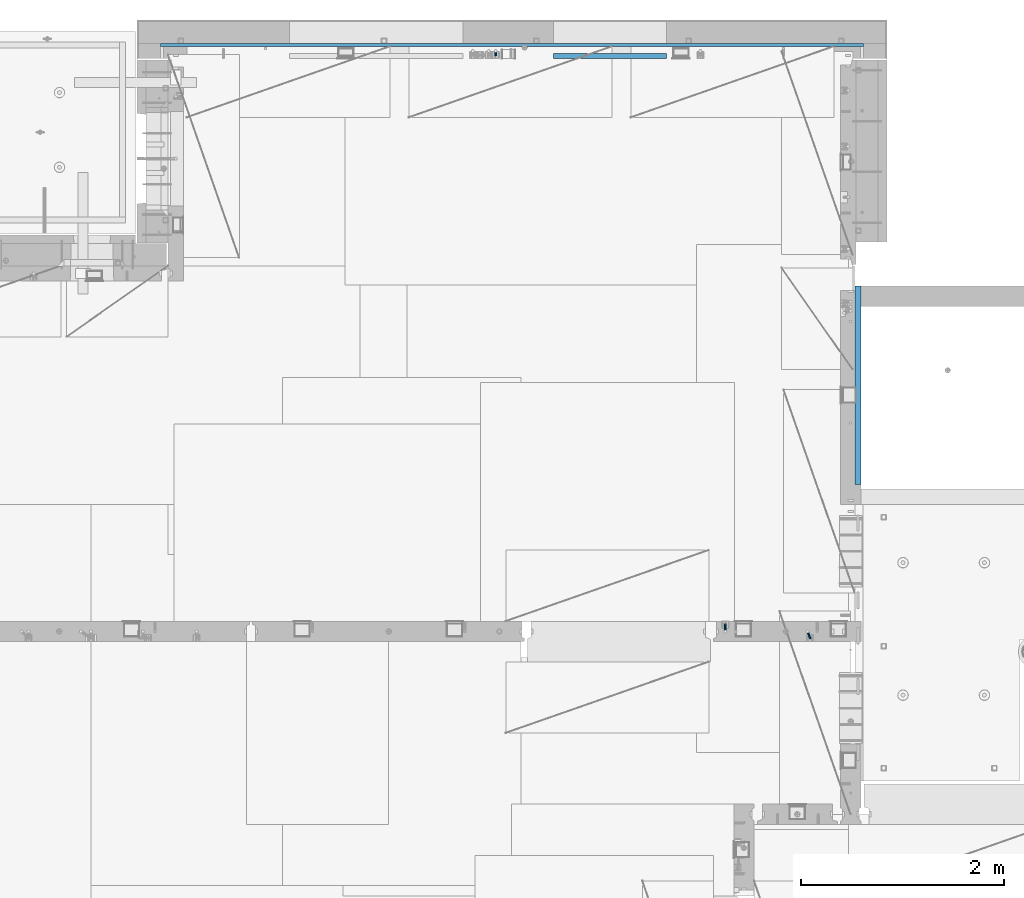
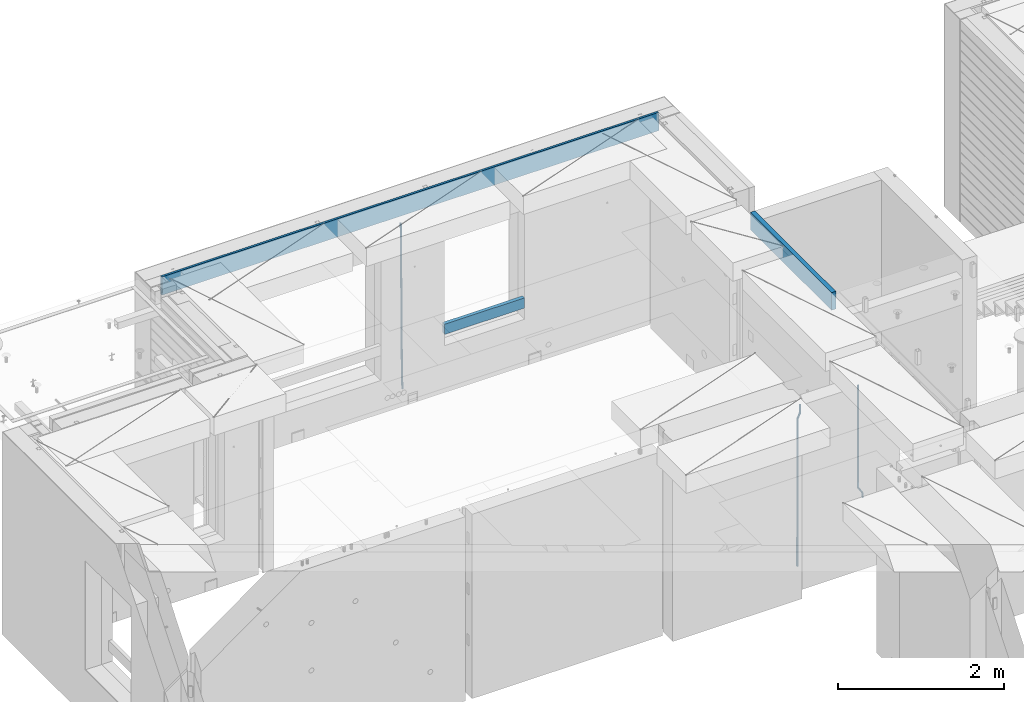
# One storey, part 112 of 334: 6 beams, 3 elements without a shape of their own.
"""IFC2X3 building model written with IfcOpenShell, lengths in millimetres."""

import ifcopenshell
import ifcopenshell.guid

model = None  # the IFC model being written
_history = None  # IfcOwnerHistory: only IFC2X3 demands one
_inside = {}  # id of a spatial element -> (the spatial element, [elements in it])
_under = {}  # id of a project, library or spatial element -> (it, [spatial elements below it])
_declared = {}  # id of a project -> (the project, [libraries it declares])
_typed = {}  # id of a type object -> (the type object, [elements of that type])
_made_of = {}  # id of a material, layer set ... -> (it, [elements and type objects made of it])


def new_model(schema):
    """Start an empty IFC model of exactly this schema.

    Asked for "IFC4X3", IfcOpenShell would pick the latest addendum, in which some entities
    have other attributes; the version numbers below select the first issue.
    IFC2X3 requires an IfcOwnerHistory on every rooted entity: one is made here for all.
    """
    global model, _history
    if schema == "IFC4X3":
        model = ifcopenshell.file(schema_version=(4, 3, 0, 0))
    else:
        model = ifcopenshell.file(schema=schema)
    _inside.clear()
    _under.clear()
    _declared.clear()
    _typed.clear()
    _made_of.clear()
    _history = None
    if model.schema == "IFC2X3":
        org = make("IfcOrganization", Name="unknown")
        user = make(
            "IfcPersonAndOrganization",
            ThePerson=make("IfcPerson", FamilyName="unknown"),
            TheOrganization=org,
        )
        app = make(
            "IfcApplication",
            ApplicationDeveloper=org,
            Version="unknown",
            ApplicationFullName="unknown",
            ApplicationIdentifier="unknown",
        )
        _history = make(
            "IfcOwnerHistory",
            OwningUser=user,
            OwningApplication=app,
            ChangeAction="ADDED",
            CreationDate=0,
        )
    return model


def make(cls, **values):
    """One entity of the class cls with the attributes given. An attribute that is None is left unset."""
    return model.create_entity(
        cls, **{name: value for name, value in values.items() if value is not None}
    )


def rooted(cls, **values):
    """An entity with a GlobalId (a new one), such as an element, a storey or a relation."""
    return make(cls, GlobalId=ifcopenshell.guid.new(), OwnerHistory=_history, **values)


def si_unit(unit_type, name, prefix=None):
    """IfcSIUnit, for example si_unit("LENGTHUNIT", "METRE", prefix="MILLI")."""
    return make("IfcSIUnit", UnitType=unit_type, Prefix=prefix, Name=name)


def assignment(units):
    """IfcUnitAssignment: the units of a project."""
    return None if units is None else make("IfcUnitAssignment", Units=units)


def point(xyz):
    """IfcCartesianPoint."""
    return None if xyz is None else make("IfcCartesianPoint", Coordinates=xyz)


def direction(xyz):
    """IfcDirection."""
    return None if xyz is None else make("IfcDirection", DirectionRatios=xyz)


def frame(location, z_axis=None, x_axis=None):
    """IfcAxis2Placement3D, a coordinate frame: its origin and axes. An axis left out is left unset."""
    return make(
        "IfcAxis2Placement3D",
        Location=point(location),
        Axis=direction(z_axis),
        RefDirection=direction(x_axis),
    )


def origin_with_axes():
    """The frame at (0, 0, 0) with the z axis (0, 0, 1) and the x axis (1, 0, 0) written out."""
    return frame((0.0, 0.0, 0.0), z_axis=(0.0, 0.0, 1.0), x_axis=(1.0, 0.0, 0.0))


def place(relative_to, where):
    """IfcLocalPlacement: puts the frame where relative to a parent placement (None: the world)."""
    return make(
        "IfcLocalPlacement", PlacementRelTo=relative_to, RelativePlacement=where
    )


def context(
    kind, dimensions, precision=None, world=None, true_north=None, identifier=None
):
    """IfcGeometricRepresentationContext, for example the 3D "Model" context."""
    return make(
        "IfcGeometricRepresentationContext",
        ContextIdentifier=identifier,
        ContextType=kind,
        CoordinateSpaceDimension=dimensions,
        Precision=precision,
        WorldCoordinateSystem=world,
        TrueNorth=true_north,
    )


def subcontext(parent, identifier, kind, view, scale=None):
    """IfcGeometricRepresentationSubContext, for example "Body" below "Model"."""
    return make(
        "IfcGeometricRepresentationSubContext",
        ContextIdentifier=identifier,
        ContextType=kind,
        ParentContext=parent,
        TargetScale=scale,
        TargetView=view,
    )


def project(units=None, contexts=None):
    """IfcProject with its units and contexts."""
    return rooted(
        "IfcProject",
        Name="project",
        RepresentationContexts=contexts,
        UnitsInContext=assignment(units),
    )


def spatial(cls, under=None, at=None, **own):
    """A site, building, storey or space (cls), placed at a placement, below another one or the project."""
    s = rooted(cls, ObjectPlacement=at, **own)
    if under is not None:
        _under.setdefault(under.id(), (under, []))[1].append(s)
    return s


def faces_of(points, faces, orient=None, outer=None):
    """IfcFace entities. A face is a list of loops; a loop is a list of indices into points, from 0.

    orient and outer hold one flag for each loop. By default every Orientation is true, the
    first loop of a face is its IfcFaceOuterBound and the others are IfcFaceBound.
    """
    made = []
    for i, loops in enumerate(faces):
        bounds = []
        for j, loop in enumerate(loops):
            is_outer = j == 0 if outer is None else outer[i][j]
            bounds.append(
                make(
                    "IfcFaceOuterBound" if is_outer else "IfcFaceBound",
                    Bound=make("IfcPolyLoop", Polygon=[points[k] for k in loop]),
                    Orientation=True if orient is None else orient[i][j],
                )
            )
        made.append(make("IfcFace", Bounds=bounds))
    return made


def faceted_brep(points, faces, orient=None, outer=None, voids=None):
    """IfcFacetedBrep: a solid bounded by flat faces; with voids (closed shells), ...WithVoids."""
    shared = [point(p) for p in points]
    hull = make("IfcClosedShell", CfsFaces=faces_of(shared, faces, orient, outer))
    if voids is None:
        return make("IfcFacetedBrep", Outer=hull)
    return make(
        "IfcFacetedBrepWithVoids",
        Outer=hull,
        Voids=[
            make(cls, CfsFaces=faces_of(shared, fs, o, b)) for cls, fs, o, b in voids
        ],
    )


def shape(context_of_items, identifier, shape_type, items):
    """IfcShapeRepresentation: the items that make up one representation, for example the "Body"."""
    return make(
        "IfcShapeRepresentation",
        ContextOfItems=context_of_items,
        RepresentationIdentifier=identifier,
        RepresentationType=shape_type,
        Items=items,
    )


def material(Name=None, Category=None):
    """IfcMaterial."""
    return make("IfcMaterial", Name=Name, Category=Category)


def made_of(thing, what):
    """Note that an element or type object is made of a material, layer set ...; save() writes the relation."""
    if what is not None:
        _made_of.setdefault(what.id(), (what, []))[1].append(thing)
    return thing


def type_object(cls, material=None, **own):
    """A type object (cls), such as IfcWallType, which elements share."""
    return made_of(rooted(cls, **own), material)


def element(
    cls,
    number,
    at=None,
    inside=None,
    cuts=None,
    type_object=None,
    material=None,
    context=None,
    identifier="Body",
    shape_type=None,
    held_by="IfcProductDefinitionShape",
    body=None,
    shapes=None,
    **own,
):
    """One element of the class cls, such as IfcWall. Its Tag is "e" and its number.

    at: its placement. inside: the storey or other place that contains it. cuts: it is an
    opening in that element (IfcRelVoidsElement). A single representation is given by context,
    identifier, shape_type and body (its items); several are given by shapes. held_by: the class
    of the entity that holds the representations. save() writes the other relations.
    """
    e = rooted(cls, Tag="e%d" % number, ObjectPlacement=at, **own)
    if body is not None:
        shapes = [shape(context, identifier, shape_type, body)]
    if shapes is not None:
        e.Representation = make(held_by, Representations=shapes)
    if inside is not None:
        _inside.setdefault(inside.id(), (inside, []))[1].append(e)
    if cuts is not None:
        rooted(
            "IfcRelVoidsElement", RelatingBuildingElement=cuts, RelatedOpeningElement=e
        )
    if type_object is not None:
        _typed.setdefault(type_object.id(), (type_object, []))[1].append(e)
    return made_of(e, material)


def aggregate(whole, parts):
    """IfcRelAggregates: a whole, such as a stair, and the parts it consists of."""
    return rooted("IfcRelAggregates", RelatingObject=whole, RelatedObjects=parts)


def save(model, path):
    """Write the relations noted so far, then the file.

    IfcRelAggregates (storeys below a building ...), IfcRelContainedInSpatialStructure (elements
    in a storey), IfcRelDefinesByType, IfcRelAssociatesMaterial and IfcRelDeclares: one each for
    every whole, place, type object, material and project.
    """
    for whole, parts in _under.values():
        aggregate(whole, parts)
    for where, things in _inside.values():
        rooted(
            "IfcRelContainedInSpatialStructure",
            RelatedElements=things,
            RelatingStructure=where,
        )
    for kind, things in _typed.values():
        rooted("IfcRelDefinesByType", RelatedObjects=things, RelatingType=kind)
    for what, things in _made_of.values():
        rooted("IfcRelAssociatesMaterial", RelatedObjects=things, RelatingMaterial=what)
    for by, libraries in _declared.values():
        rooted("IfcRelDeclares", RelatingContext=by, RelatedDefinitions=libraries)
    model.write(path)


model = new_model("IFC2X3")

# Units and contexts
model_context = context("Model", 3, precision=1e-05, world=origin_with_axes())
body_context = subcontext(model_context, "Body", "Model", "MODEL_VIEW")
ifc_project = project(units=[si_unit("LENGTHUNIT", "METRE", prefix="MILLI"), si_unit("AREAUNIT", "SQUARE_METRE"), si_unit("VOLUMEUNIT", "CUBIC_METRE"), si_unit("MASSUNIT", "GRAM", prefix="KILO"), si_unit("TIMEUNIT", "SECOND"), si_unit("PLANEANGLEUNIT", "RADIAN"), si_unit("SOLIDANGLEUNIT", "STERADIAN"), si_unit("THERMODYNAMICTEMPERATUREUNIT", "DEGREE_CELSIUS"), si_unit("LUMINOUSINTENSITYUNIT", "LUMEN")], contexts=[model_context])

# Site, building, storey
site_placement = place(None, origin_with_axes())
site = spatial("IfcSite", under=ifc_project, at=site_placement, CompositionType="ELEMENT")
building_placement = place(site_placement, origin_with_axes())
building = spatial("IfcBuilding", under=site, at=building_placement, CompositionType="ELEMENT")
storey_placement = place(building_placement, origin_with_axes())
storey = spatial("IfcBuildingStorey", under=building, at=storey_placement, Name="3", CompositionType="ELEMENT", Elevation=0.0)

# Assembly, beams
assembly_1_placement = place(storey_placement, origin_with_axes())
assembly_1 = element("IfcElementAssembly", 1, at=assembly_1_placement, inside=storey, AssemblyPlace="NOTDEFINED", PredefinedType="REINFORCEMENT_UNIT")
ifc_material_1 = material()
beam_type_1 = type_object("IfcBeamType", Name="D20", PredefinedType="NOTDEFINED")
beam_1_placement = place(assembly_1_placement, frame((17285.016478657, 16980.0, 90407.5), z_axis=(-0.000415599999849952, -0.999999913638316, 0.0), x_axis=(-6.05680000062309e-05, -4.00000390151988e-09, -0.999999998165759)))
beam_1 = element("IfcBeam", 2, at=beam_1_placement, type_object=beam_type_1, material=ifc_material_1, Name="JM20", ObjectType="D20", context=body_context, shape_type="Brep", body=[
    faceted_brep([(0.000459931368823163, -9.99999998942076, 0.0), (0.000325058383168653, -7.07106780439426, -7.07106781187031), (1498.53016917036, -7.00214571310062, -7.07110244258729), (1498.53030404639, -9.93107788867201, -3.46394881489687e-05), (0.0, 0.0, -10.0), (1498.52984388257, 0.0689220912790915, -10.0000346307206), (-0.000325382832670584, 7.07106780437971, -7.07106781186667), (1498.52951872915, 7.13998989566971, -7.07110244258365), (-0.000459931412478909, 9.9999999894244, 0.0), (1498.52938418057, 10.0689220807144, -3.46307206200436e-05), (-0.000325058426824398, 7.07106780439062, 7.07106781186667), (1498.52951905355, 7.13998989568427, 7.07103318114605), (0.0, 0.0, 10.0), (1498.52984434133, 0.0689220913009194, 9.99996536927938), (0.000325382789014839, -7.07106780437607, 7.07106781186303), (1498.53016949476, -7.00214571308607, 7.07103318114241), (1512.41720874803, -5.73582294623338, -3.78448857876356), (1509.77427058959, -8.90577003658836, 2.66104918808924), (1506.12781116656, -6.30933666407145, 8.86914963737581), (1503.61387695429, 0.5325217154641, 11.203191722434), (1503.70509651935, 7.6119372551475, 8.29592524499458), (1506.34803467779, 10.7818843455061, 1.85038747814542), (1509.99449410092, 8.18545097300375, -4.35771297110477), (1512.50842831319, 1.34359259344637, -6.6917550561775), (1523.10793428493, 4.85819958866705, 2.43339327473223), (1522.94729923509, -2.24423288682374, 5.28089974098111), (1518.68801206884, 11.068066365151, 3.12656423834051), (1512.27666307625, 12.7477117054659, 6.95436248228361), (1507.62956859401, 8.91322214926913, 11.6745157093537), (1507.46893354415, 1.81078967378926, 14.5220221756208), (1511.88885576031, -4.39907710268017, 13.8288512120525), (1518.30020474852, -6.07872245333419, 10.0010529750907), (1556.47190306216, 16.2553988912259, 53.3150705600565), (1551.82480858495, 12.4209093455574, 58.0352237797015), (1556.63253811194, 23.3578313666767, 50.4675640938258), (1552.2126158958, 29.5676981431861, 51.1607350575687), (1545.80126690332, 31.2473434836029, 54.9885333017664), (1541.1541724212, 27.4128539274789, 59.7086865290003), (1540.99353737144, 20.3104214520208, 62.5561929952273), (1545.41345958759, 14.100554675515, 61.8630220314881), (1560.39637396604, 17.5567067062075, 56.6936612143036), (1557.75345399432, 14.386777545431, 63.1392152562548), (1554.10697584673, 16.9832211248868, 69.3473004384578), (1551.59299696748, 23.8250760096525, 71.6813046576062), (1551.6841720884, 30.9044764000282, 68.7739998967481), (1554.32709206025, 34.0744055607975, 62.3284458548405), (1557.97357020773, 31.4779619813417, 56.1203606726085), (1560.48754908697, 24.6361070965759, 53.7863564534418), (1565.57152260729, 25.0997628321384, 54.9895678972971), (1565.57195097132, 18.0287166318594, 57.9185522284643), (1565.57109441068, 32.1708522292429, 57.9184479422765), (1565.5709172132, 35.0998365550477, 64.9894941556158), (1565.57109481466, 32.1709565155361, 72.0605835657152), (1565.57152317863, 25.0999103152426, 74.9895678968714), (1565.5719513753, 18.0288209181526, 72.0606878518956), (1565.57212857006, 15.0998365824271, 64.9896416479532), (1617.49891294041, 18.0318617339399, 57.9185507229813), (1617.49909054188, 15.1029816944028, 64.9896401330443), (1617.49848457637, 25.1029079342443, 54.989566391796), (1617.49805637961, 32.1739973313524, 57.9184464367172), (1617.49787918197, 35.1029816571718, 64.9894926500019), (1617.49805678344, 32.1741016176347, 72.0605820600649), (1617.49848514747, 25.1030554173267, 74.9895663912539), (1617.49891334424, 18.0319660202294, 72.060686346329)], [[[0, 1, 2, 3]], [[1, 4, 5, 2]], [[4, 6, 7, 5]], [[6, 8, 9, 7]], [[8, 10, 11, 9]], [[10, 12, 13, 11]], [[12, 14, 15, 13]], [[14, 0, 3, 15]], [[14, 12, 10, 8, 6, 4, 1, 0]], [[3, 2, 16, 17]], [[15, 3, 17, 18]], [[13, 15, 18, 19]], [[11, 13, 19, 20]], [[9, 11, 20, 21]], [[7, 9, 21, 22]], [[5, 7, 22, 23]], [[2, 5, 23, 16]], [[23, 24, 25, 16]], [[22, 26, 24, 23]], [[21, 27, 26, 22]], [[20, 28, 27, 21]], [[19, 29, 28, 20]], [[18, 30, 29, 19]], [[17, 31, 30, 18]], [[16, 25, 31, 17]], [[31, 25, 32, 33]], [[25, 24, 34, 32]], [[24, 26, 35, 34]], [[26, 27, 36, 35]], [[27, 28, 37, 36]], [[28, 29, 38, 37]], [[29, 30, 39, 38]], [[30, 31, 33, 39]], [[33, 32, 40, 41]], [[39, 33, 41, 42]], [[38, 39, 42, 43]], [[37, 38, 43, 44]], [[36, 37, 44, 45]], [[35, 36, 45, 46]], [[34, 35, 46, 47]], [[32, 34, 47, 40]], [[47, 48, 49, 40]], [[46, 50, 48, 47]], [[45, 51, 50, 46]], [[44, 52, 51, 45]], [[43, 53, 52, 44]], [[42, 54, 53, 43]], [[41, 55, 54, 42]], [[40, 49, 55, 41]], [[55, 49, 56, 57]], [[49, 48, 58, 56]], [[48, 50, 59, 58]], [[50, 51, 60, 59]], [[51, 52, 61, 60]], [[52, 53, 62, 61]], [[53, 54, 63, 62]], [[54, 55, 57, 63]], [[58, 59, 60, 61, 62, 63, 57, 56]]]),
])
beam_2_placement = place(assembly_1_placement, frame((16475.016478657, 16980.0, 90407.5), z_axis=(-0.000415599999849952, -0.999999913638316, 0.0), x_axis=(-6.05680000062309e-05, -4.00000390151988e-09, -0.999999998165759)))
beam_2 = element("IfcBeam", 3, at=beam_2_placement, type_object=beam_type_1, material=ifc_material_1, Name="JM20", ObjectType="D20", context=body_context, shape_type="Brep", body=[
    faceted_brep([(-0.00060564729210455, -9.99999998165731, 0.0), (-0.000428079845733009, -7.07106779890455, -7.07106781186667), (109.663992146438, -7.07770969181365, -7.07106505070624), (109.663814574931, -10.0066418742208, 2.76014907285571e-06), (0.0, 0.0, -10.0), (109.664420484245, -0.00664189292001538, -9.99999723883957), (0.00042843479604926, 7.07106779888636, -7.07106781186303), (109.66484867355, 7.0644259059809, -7.07106505070988), (0.00060564729210455, 9.99999998166459, 3.63797880709171e-12), (109.665025886861, 9.99335808875549, 2.76115679298528e-06), (0.000428079845733009, 7.07106779890819, 7.07106781186667), (109.664848315049, 7.06442590600273, 7.07107057301982), (0.0, 0.0, 10.0), (109.664419977242, -0.00664189288727357, 10.0000027611604), (-0.000428434810601175, -7.07106779888272, 7.07106781186667), (109.663991787937, -7.07770969179182, 7.07107057302346), (123.019465653822, -0.00769783093346632, 8.49481275451399), (122.368218641306, 7.06342149385819, 5.63932810477127), (120.794596020874, 9.9924781119953, -1.25436342694593), (119.220404581531, 7.06367038153257, -8.14803083615698), (118.567784318744, -0.00734585062309634, -11.0034572490222), (119.219031331319, -7.07846517541839, -8.14797259927946), (120.79265395175, -10.0075217935628, -1.25428106757317), (122.366845391021, -7.07871406308914, 5.63938634164515), (134.432358609134, -7.0801380724879, 1.41616492140383), (135.704448506891, -0.00919495208290755, 4.05476198080942), (131.363125973905, -10.0087693538771, -4.95420191149606), (128.294665451453, -7.07953630984775, -11.3246640276848), (127.024439601548, -0.00834393120385357, -13.9634911148387), (128.296529499246, 7.06259918918295, -11.3248940553931), (131.365762135116, 9.99123047017565, -4.95452722118716), (134.434222657001, 7.06199742654644, 1.41593489364823), (232.333181448281, -7.09406463311461, -61.4435769522424), (235.401641971155, -10.0232976755033, -55.0731148385494), (231.062955598129, -0.0228722546671634, -64.0824040398293), (232.335045495653, 7.04807086590154, -61.4438069808093), (235.404278131435, 9.97670214732716, -55.0734401467271), (238.472738653494, 7.0474691041527, -48.7029780316807), (239.742964503646, -0.0237232742911146, -46.0641509440975), (238.470874606137, -7.09466639485981, -48.7027480031138), (248.152386176487, -0.0244396446978499, -49.0133708264948), (247.497266945589, 7.04670033489674, -51.8679184167595), (245.915123067214, 9.97580676374491, -58.7596380886316), (244.332752967632, 7.04704882145597, -65.6514539264135), (243.677087590491, -0.0239468102772662, -68.5062336817027), (244.33220682136, -7.09508678989368, -65.651686091438), (245.914350699837, -10.0241932187346, -58.7599664195659), (247.496720799376, -7.09543527645292, -51.8681505817658), (256.999396693936, -7.09531210125351, -52.9566469665442), (257.006072236094, -0.0243248818260327, -50.0275278254703), (256.982439129002, -10.0240497531304, -60.0277750206151), (256.965133057005, -7.09492303985826, -67.0987410777925), (256.957616135987, -0.0237746659149707, -70.0274691179584), (256.964291678203, 7.04721255350523, -67.0983499769027), (256.981249241362, 9.97595020465087, -60.027221921624), (256.998555315135, 7.04682349210998, -52.9562558656398), (2308.84129044529, -6.97271028710384, -72.0700484847293), (2308.85859651901, -9.9018369995174, -64.9990824287343), (2308.83377352433, 0.0984380867485015, -74.9987765249425), (2308.84044906651, 7.16942530619053, -72.0696573839123), (2308.85740662973, 10.0981629574344, -64.9985293286554), (2308.87471270347, 7.16903624502447, -57.9275632726531), (2308.88222962443, 0.0978878711684956, -54.9988352324472), (2308.87555408225, -6.9730993482699, -57.9279543734738), (2309.36197244871, -6.97267927451685, -72.0713099986351), (2309.37071429225, -9.90180649703325, -65.000323193126), (2309.3579998037, 0.0984693104364851, -75.0000466259553), (2309.3611234788, 7.16945631832277, -72.0709188794244), (2309.36951366749, 10.0981934592819, -64.9997700670392), (2309.37825551104, 7.16906623676914, -57.9287832615337), (2309.38222815606, 0.0979176518158056, -55.0000466342135), (2309.37910448095, -6.97306935607776, -57.929174380748), (2309.8826559803, -6.97264773775169, -72.0713100117428), (2309.88283356852, -9.90177547898566, -65.0003232060189), (2309.88222762165, 0.0985010618751403, -75.0000466391502), (2309.88179941924, 7.16948785463319, -72.0709188925321), (2309.88162220824, 10.0982244766819, -64.9997700799322), (2309.88179979647, 7.16909673544797, -57.9287832742084), (2309.88222815514, 0.0979479358211393, -55.0000466468009), (2309.88265635754, -6.97303885693691, -57.9291743934191), (2417.50042500655, -6.96612954309967, -72.0713127206036), (2417.50060259478, -9.89525728433364, -65.0003259148798), (2417.49999664789, 0.105019256523519, -75.0000493480147), (2417.49956844548, 7.17600604928157, -72.0709216013965), (2417.49939123449, 10.1047426713303, -64.9997727887931), (2417.49956882271, 7.17561493009634, -57.9287859830729), (2417.49999718138, 0.104466130473156, -55.0000493556618), (2417.50042538378, -6.96652066228489, -57.9291771022799)], [[[0, 1, 2, 3]], [[1, 4, 5, 2]], [[4, 6, 7, 5]], [[6, 8, 9, 7]], [[8, 10, 11, 9]], [[10, 12, 13, 11]], [[12, 14, 15, 13]], [[14, 0, 3, 15]], [[14, 12, 10, 8, 6, 4, 1, 0]], [[11, 13, 16, 17]], [[9, 11, 17, 18]], [[7, 9, 18, 19]], [[5, 7, 19, 20]], [[2, 5, 20, 21]], [[3, 2, 21, 22]], [[15, 3, 22, 23]], [[13, 15, 23, 16]], [[23, 24, 25, 16]], [[22, 26, 24, 23]], [[21, 27, 26, 22]], [[20, 28, 27, 21]], [[19, 29, 28, 20]], [[18, 30, 29, 19]], [[17, 31, 30, 18]], [[16, 25, 31, 17]], [[26, 27, 32, 33]], [[27, 28, 34, 32]], [[28, 29, 35, 34]], [[29, 30, 36, 35]], [[30, 31, 37, 36]], [[31, 25, 38, 37]], [[25, 24, 39, 38]], [[24, 26, 33, 39]], [[37, 38, 40, 41]], [[36, 37, 41, 42]], [[35, 36, 42, 43]], [[34, 35, 43, 44]], [[32, 34, 44, 45]], [[33, 32, 45, 46]], [[39, 33, 46, 47]], [[38, 39, 47, 40]], [[47, 48, 49, 40]], [[46, 50, 48, 47]], [[45, 51, 50, 46]], [[44, 52, 51, 45]], [[43, 53, 52, 44]], [[42, 54, 53, 43]], [[41, 55, 54, 42]], [[40, 49, 55, 41]], [[50, 51, 56, 57]], [[51, 52, 58, 56]], [[52, 53, 59, 58]], [[53, 54, 60, 59]], [[54, 55, 61, 60]], [[55, 49, 62, 61]], [[49, 48, 63, 62]], [[48, 50, 57, 63]], [[57, 56, 64, 65]], [[56, 58, 66, 64]], [[58, 59, 67, 66]], [[59, 60, 68, 67]], [[60, 61, 69, 68]], [[61, 62, 70, 69]], [[62, 63, 71, 70]], [[63, 57, 65, 71]], [[65, 64, 72, 73]], [[64, 66, 74, 72]], [[66, 67, 75, 74]], [[67, 68, 76, 75]], [[68, 69, 77, 76]], [[69, 70, 78, 77]], [[70, 71, 79, 78]], [[71, 65, 73, 79]], [[73, 72, 80, 81]], [[72, 74, 82, 80]], [[74, 75, 83, 82]], [[75, 76, 84, 83]], [[76, 77, 85, 84]], [[77, 78, 86, 85]], [[78, 79, 87, 86]], [[79, 73, 81, 87]], [[82, 83, 84, 85, 86, 87, 81, 80]]]),
])
aggregate(assembly_1, [beam_1, beam_2])

# Assembly, beam
assembly_2_placement = place(storey_placement, origin_with_axes())
assembly_2 = element("IfcElementAssembly", 4, at=assembly_2_placement, inside=storey, AssemblyPlace="NOTDEFINED", PredefinedType="REINFORCEMENT_UNIT")
ifc_material_2 = material(Name="CONCRETE/C25/30")
beam_type_2 = type_object("IfcBeamType", Name="260X60", PredefinedType="NOTDEFINED")
beam_3_placement = place(assembly_2_placement, frame((17779.9999105288, 18424.9992663657, 90600.0), z_axis=(0.0, 0.0, 1.0), x_axis=(0.0, 1.0, 0.0)))
beam_3 = element("IfcBeam", 5, at=beam_3_placement, type_object=beam_type_2, material=ifc_material_2, ObjectType="260X60", context=body_context, shape_type="Brep", body=[
    faceted_brep([(0.0, 30.0, -130.0), (0.0, 30.0, 130.0), (1954.9989445891, 30.0, 130.0), (1954.9989445891, 30.0, -130.0), (0.0, -30.0, 130.0), (1954.9989445891, -30.0, 130.0), (0.0, -30.0, -130.0), (1954.9989445891, -30.0, -130.0)], [[[0, 1, 2, 3]], [[1, 4, 5, 2]], [[4, 6, 7, 5]], [[6, 0, 3, 7]], [[5, 7, 3, 2]], [[6, 4, 1, 0]]]),
])
aggregate(assembly_2, [beam_3])

# Assembly, beams
assembly_3_placement = place(storey_placement, origin_with_axes())
assembly_3 = element("IfcElementAssembly", 6, at=assembly_3_placement, inside=storey, AssemblyPlace="NOTDEFINED", PredefinedType="REINFORCEMENT_UNIT")
beam_type_3 = type_object("IfcBeamType", Name="D25", PredefinedType="NOTDEFINED")
beam_4_placement = place(assembly_3_placement, frame((14215.0000000039, 22654.9999977209, 87990.0), z_axis=(-0.000205762999925498, 0.999642804629538, -0.0267249099901004), x_axis=(4.30000201928125e-08, 0.0267249099948059, 0.999642825806181)))
beam_4 = element("IfcBeam", 7, at=beam_4_placement, type_object=beam_type_3, material=ifc_material_1, Name="JM25", ObjectType="D25", context=body_context, shape_type="Brep", body=[
    faceted_brep([(-7.41420080885291e-08, -12.5, -3.63797880709171e-12), (-6.42030499875546e-08, -10.8253175473074, -6.25000000000364), (60.4103898235917, -10.8253175318459, -6.2499999938409), (60.4103898269532, -12.4999999845422, 6.16273609921336e-09), (-3.70782800018787e-08, -6.25000000000364, -10.8253175473074), (60.4103898202884, -6.24999998454587, -10.8253175411446), (-1.45519152283669e-11, -3.63797880709171e-12, -12.5), (60.4103898179019, 1.54577719513327e-08, -12.4999999938373), (3.70637280866504e-08, 6.25, -10.8253175473074), (60.410389817087, 6.25000001545777, -10.825317541141), (6.42030499875546e-08, 10.8253175473001, -6.25000000000364), (60.410389818062, 10.8253175627578, -6.24999999383726), (7.41420080885291e-08, 12.4999999999927, 0.0), (60.4103898205503, 12.5000000154541, 6.16273609921336e-09), (6.42176019027829e-08, 10.8253175473001, 6.24999999999636), (60.4103898238973, 10.8253175627651, 6.2500000061591), (3.70928319171071e-08, 6.24999999999636, 10.8253175473037), (60.4103898272151, 6.25000001546141, 10.8253175534664), (1.45519152283669e-11, -3.63797880709171e-12, 12.4999999999964), (60.4103898296162, 1.54541339725256e-08, 12.5000000061591), (-3.7049176171422e-08, -6.25000000000364, 10.8253175473001), (60.4103898304165, -6.24999998454587, 10.8253175534701), (-6.41884980723262e-08, -10.8253175473074, 6.25), (60.4103898294561, -10.8253175318459, 6.25000000616637), (61.0324985728803, -10.8253175316895, -6.24999999377542), (60.991802792938, -12.4999999843931, 6.22458173893392e-09), (61.0622854283865, -6.24999998437852, -10.8253175410755), (61.0731819955545, 1.5628756955266e-08, -12.4999999937718), (61.0622685480339, 6.25000001562512, -10.8253175410791), (61.032469335245, 10.8253175629216, -6.24999999377178), (60.9917690322181, 12.5000000156033, 6.22458173893392e-09), (60.9510732522613, 10.8253175629034, 6.25000000621731), (60.9212863967696, 6.25000001558874, 10.8253175535247), (60.9103898296162, 1.55814632307738e-08, 12.5000000062137), (60.9213032771368, -6.24999998441126, 10.8253175535174), (60.9511024898966, -10.8253175317113, 6.25000000621731), (61.6545545670233, -10.8253158516927, -6.24189838219536), (61.573166454793, -12.499998414296, 0.00757164385504439), (61.7141257553885, -6.24999822394238, -10.8168280205282), (61.7359179680789, 1.80548886419274e-06, -12.491368569139), (61.7140919992817, 6.25000177601396, -10.8168282403167), (61.6544960997562, 10.8253192428383, -6.2418987628771), (61.5730989426083, 12.5000015856094, 0.0075712042817031), (61.4917108303925, 10.8253190230062, 6.25704123032847), (61.4321396420273, 6.25000139525582, 10.8319708686649), (61.4103474293224, 1.36582457344048e-06, 12.5065114172721), (61.4321733981196, -6.24999860470052, 10.8319710884571), (61.4917692976451, -10.8253160715249, 6.25704161101385), (176.524302641745, -10.8250056210964, -4.74584321979273), (176.442914529529, -12.4996881836996, 1.50362680625403), (176.583873830095, -6.24968799334965, -9.3207728581292), (176.605666042786, 0.000312036081595579, -10.9953134067364), (176.583840074018, 6.25031200660669, -9.32077307791769), (176.524244174492, 10.8256294734347, -4.74584360047811), (176.44284701733, 12.5003118162058, 1.50362636668069), (176.361458905099, 10.8256292535989, 7.75309639272746), (176.301887716749, 6.25031162585219, 12.3280260310676), (176.280095504058, 0.000311596420942806, 14.0025665796711), (176.301921472827, -6.24968837410415, 12.3280262508561), (176.361517372367, -10.8250058409321, 7.75309677341284), (177.085397012124, -10.8250041057399, -4.73853556792164), (176.983633547483, -12.4996867233749, 1.51066909103247), (177.159881729676, -6.24968643771717, -9.31327097355097), (177.187129580227, 0.000313606451527448, -10.987740468332), (177.159839524218, 6.25031356221734, -9.31327130338468), (177.085323910098, 10.8256309887511, -4.73853613920801), (176.983549136537, 12.5003132764905, 1.51066843136869), (176.881785671867, 10.8256306588555, 7.7598730903228), (176.80730095433, 6.25031299082912, 12.3346084959521), (176.780053103794, 0.000312946667690994, 14.0090779907332), (176.807343159802, -6.2496870091054, 12.3346088257895), (176.881858773908, -10.8250044356355, 7.7598736616128), (177.646431799818, -10.8250018318176, -4.72756919822132), (177.524295146417, -12.4996845320202, 1.52123723245313), (177.735828462886, -6.24968410334986, -9.30201312475765), (177.768531371941, 0.00031596292683389, -10.9763759912421), (177.735777808921, 6.25031589654827, -9.30201361973741), (177.646344064575, 10.8256332626152, -4.72757005553649), (177.524193838486, 12.5003154677688, 1.52123624250817), (177.402057185071, 10.8256327675663, 7.77004267317898), (177.312660521988, 6.2503150390985, 12.3444865997226), (177.279957612933, 0.00031497282179771, 14.0188494661961), (177.312711175953, -6.24968496079964, 12.3444870946951), (177.402144920314, -10.8250023268702, 7.77004353049415), (299.377443161706, -10.8245084454466, -2.34813158632096), (299.255306508276, -12.4991911456491, 3.90067484435349), (299.466839824803, -6.24919071697514, -6.92257551286093), (299.499542733873, 0.0008093492979242, -8.59693837933446), (299.466789170867, 6.250809282923, -6.92257600783341), (299.377355426492, 10.8261266489935, -2.34813244364341), (299.255205200388, 12.5008088541435, 3.90067385440125), (299.133068546944, 10.826126153941, 10.1494802850757), (299.043671883861, 6.25080842546959, 14.7239242116229), (299.010968974762, 0.000808359200163977, 16.3982870780892), (299.043722537797, -6.24919157442127, 14.7239247065918), (299.133156282158, -10.8245089404954, 10.1494811423981), (299.98561436501, -10.8245059804758, -2.33624385599614), (299.97179243555, -12.4991882411778, 3.91467976726199), (299.995742293278, -6.24918857328521, -6.91223722345239), (299.999447243041, 0.000811375455668895, -8.58716690387519), (299.995736475976, 6.25081142679483, -6.91223684201032), (299.985604289133, 10.8261291142808, -2.33624319533556), (299.971750386685, 12.5008117588586, 3.91467993563856), (299.957928457196, 10.8261294971744, 10.1656035610831), (299.947800528913, 6.25081208998381, 14.7415969285394), (299.944095579151, 0.00081214124293183, 16.4165266089549), (299.947806346216, -6.24918791008895, 14.7415965471009), (299.957938533058, -10.8245055975785, 10.1656029004225), (300.593832239858, -10.8245078794353, -2.34543881707941), (300.688302931099, -12.4991904788549, 3.90384712594823), (300.524685350189, -6.24919022474205, -6.92023371784308), (300.499390115292, 0.000809814544481924, -8.59472497713432), (300.524724372954, 6.25080977519247, -6.92023401429469), (300.593899829313, 10.8261272150703, -2.34543933054374), (300.688380976673, 12.5008095210287, 3.90384653304136), (300.782851667915, 10.8261269216127, 10.1531324760799), (300.851998557599, 6.25080926691589, 14.7279273768363), (300.877293792495, 0.000809227632998955, 16.4024186361276), (300.851959534804, -6.24919073302226, 14.7279276732806), (300.782784078474, -10.8245081728965, 10.153132989537), (2293.32930409742, -10.8307295605009, -32.4713622331001), (2293.42377478865, -12.5054121599169, -26.2220762900724), (2293.26015720774, -6.2554119058077, -37.0461571338565), (2293.23486197284, -0.00541186651753378, -38.7206483931477), (2293.26019623051, 6.24458809413409, -37.0461574303008), (2293.32937168686, 10.8199055340046, -32.4713627465644), (2293.42385283421, 12.4945878399631, -26.2220768829684), (2293.51832352545, 10.8199052405434, -19.972790939948), (2293.58747041514, 6.24458758585388, -15.3979960391844), (2293.61276565003, -0.00541245343265473, -13.7235047798931), (2293.58743139236, -6.25541241408428, -15.3979957427327), (2293.51825593603, -10.8307298539585, -19.9727904264691), (2294.0420846676, -10.8307317859326, -32.4821379598216), (2294.03681932652, -12.5054140739521, -26.2313442200393), (2294.06778164886, -6.2554144273563, -37.0583666982457), (2294.10702478497, -0.00541458957013674, -38.7338336404937), (2294.14929890928, 6.24458531819619, -37.0595987724118), (2294.18327670435, 10.8199028679592, -32.4842719748667), (2294.1998538474, 12.4945854171456, -26.2338083683717), (2294.19458850632, 10.819903129126, -19.9830146285858), (2294.16889152506, 6.24458577054975, -15.4067858901581), (2294.12964838895, -0.0054140672327776, -13.7313189479173), (2294.08737426462, -6.2554139749991, -15.4055538159919), (2294.05339646956, -10.8307315247621, -19.9808806135297), (2294.75482297382, -10.84002603931, -32.4726521173216), (2294.64982751427, -12.513407826169, -26.2231856868602), (2294.87535820232, -6.26594539088183, -37.0476186524102), (2294.97913588268, -0.0167870967634371, -38.7222267036377), (2295.0383488692, 6.23299192477134, -37.0477663960555), (2295.03713108998, 10.8087684320271, -32.4729080168181), (2294.97580884799, 12.4844668051373, -26.2234811741473), (2294.87081338844, 10.8110850182784, -19.9740147436787), (2294.7502781599, 6.23700436985018, -15.3990482086047), (2294.64650047956, -0.0121539242718427, -13.7244401573698), (2294.58728749304, -6.26193294580662, -15.3989004649666), (2294.58850527227, -10.8377094530588, -19.9737588441894), (2316.44667268227, -11.1228921988077, -32.1839550346631), (2316.34167722271, -12.7962739856739, -25.9344886042054), (2316.56720791078, -6.54881155039038, -36.7589215697517), (2316.67098559113, -0.299653256264719, -38.4335296209792), (2316.73019857766, 5.95012576527006, -36.759069313397), (2316.72898079845, 10.5259022725259, -32.1842109341669), (2316.66765855643, 12.2016006456361, -25.9347840914961), (2316.56266309689, 10.5282188587698, -19.6853176610275), (2316.44212786836, 5.95413821035254, -15.1103511259389), (2316.33835018802, -0.295020083769487, -13.4357430747186), (2316.27913720149, -6.54479910530426, -15.1102033823008), (2316.28035498071, -11.1205756125637, -19.685061761531), (2317.13234804722, -11.1318335458927, -32.1748293731798), (2317.04181141085, -12.8054038787741, -25.9251705100723), (2317.2154741603, -6.5572650749491, -36.7502937866229), (2317.26891617525, -0.307450393454928, -38.4255717558117), (2317.27835434731, 5.94297770185585, -36.7517739018112), (2317.24125972588, 10.5192220504723, -32.1773930078925), (2317.16757178486, 12.1950816748285, -25.9281307404563), (2317.0770351485, 10.5215113419545, -19.6784718773561), (2316.99390903539, 5.94694287101083, -15.1030074639057), (2316.94046702047, -0.302871810494253, -13.4277294947169), (2316.9310288484, -6.55329990579412, -15.1015273487101), (2316.96812346982, -11.1295442544142, -19.6759082426288), (2317.81808136747, -11.1298054502913, -32.1659056455355), (2317.74200467508, -12.803315894289, -25.9160547315114), (2317.86379538118, -6.55536082026447, -36.7418676070083), (2317.8668976831, -0.305700748642266, -38.417815303761), (2317.82655701396, 5.94458339541234, -36.7446799039099), (2317.75358262347, 10.5207330230332, -32.1707766866384), (2317.66752794063, 12.1965725370646, -25.9216793252963), (2317.59145124823, 10.5230620930706, -19.6718284112721), (2317.54573723453, 5.94861746304377, -15.0958664497994), (2317.54263493262, -0.301042608574789, -13.4199187530394), (2317.58297560175, -6.55132675263303, -15.0930541529051), (2317.65594999224, -11.1274763802539, -19.6669573701693), (2417.81884292323, -10.831603083323, -30.8687911350135), (2417.74276623082, -12.505113527317, -24.618940220982), (2417.86455693691, -6.25715845329614, -35.4447530964935), (2417.86765923884, -0.00749838167394046, -37.1207007932499), (2417.82731856969, 6.24278576237703, -35.4475653933878), (2417.75434417921, 10.8189353900088, -30.8736621761236), (2417.66828949639, 12.494774904033, -24.6245648147851), (2417.59221280397, 10.8212644600353, -18.3747139007501), (2417.54649879028, 6.2468198300121, -13.79875193927), (2417.54339648837, -0.00284024161010166, -12.1228042425173), (2417.5837371575, -6.25312438566107, -13.795939642383), (2417.65671154798, -10.8292740132893, -18.3698428596399)], [[[0, 1, 2, 3]], [[1, 4, 5, 2]], [[4, 6, 7, 5]], [[6, 8, 9, 7]], [[8, 10, 11, 9]], [[10, 12, 13, 11]], [[12, 14, 15, 13]], [[14, 16, 17, 15]], [[16, 18, 19, 17]], [[18, 20, 21, 19]], [[20, 22, 23, 21]], [[22, 0, 3, 23]], [[22, 20, 18, 16, 14, 12, 10, 8, 6, 4, 1, 0]], [[3, 2, 24, 25]], [[2, 5, 26, 24]], [[5, 7, 27, 26]], [[7, 9, 28, 27]], [[9, 11, 29, 28]], [[11, 13, 30, 29]], [[13, 15, 31, 30]], [[15, 17, 32, 31]], [[17, 19, 33, 32]], [[19, 21, 34, 33]], [[21, 23, 35, 34]], [[23, 3, 25, 35]], [[25, 24, 36, 37]], [[24, 26, 38, 36]], [[26, 27, 39, 38]], [[27, 28, 40, 39]], [[28, 29, 41, 40]], [[29, 30, 42, 41]], [[30, 31, 43, 42]], [[31, 32, 44, 43]], [[32, 33, 45, 44]], [[33, 34, 46, 45]], [[34, 35, 47, 46]], [[35, 25, 37, 47]], [[37, 36, 48, 49]], [[36, 38, 50, 48]], [[38, 39, 51, 50]], [[39, 40, 52, 51]], [[40, 41, 53, 52]], [[41, 42, 54, 53]], [[42, 43, 55, 54]], [[43, 44, 56, 55]], [[44, 45, 57, 56]], [[45, 46, 58, 57]], [[46, 47, 59, 58]], [[47, 37, 49, 59]], [[49, 48, 60, 61]], [[48, 50, 62, 60]], [[50, 51, 63, 62]], [[51, 52, 64, 63]], [[52, 53, 65, 64]], [[53, 54, 66, 65]], [[54, 55, 67, 66]], [[55, 56, 68, 67]], [[56, 57, 69, 68]], [[57, 58, 70, 69]], [[58, 59, 71, 70]], [[59, 49, 61, 71]], [[61, 60, 72, 73]], [[60, 62, 74, 72]], [[62, 63, 75, 74]], [[63, 64, 76, 75]], [[64, 65, 77, 76]], [[65, 66, 78, 77]], [[66, 67, 79, 78]], [[67, 68, 80, 79]], [[68, 69, 81, 80]], [[69, 70, 82, 81]], [[70, 71, 83, 82]], [[71, 61, 73, 83]], [[73, 72, 84, 85]], [[72, 74, 86, 84]], [[74, 75, 87, 86]], [[75, 76, 88, 87]], [[76, 77, 89, 88]], [[77, 78, 90, 89]], [[78, 79, 91, 90]], [[79, 80, 92, 91]], [[80, 81, 93, 92]], [[81, 82, 94, 93]], [[82, 83, 95, 94]], [[83, 73, 85, 95]], [[85, 84, 96, 97]], [[84, 86, 98, 96]], [[86, 87, 99, 98]], [[87, 88, 100, 99]], [[88, 89, 101, 100]], [[89, 90, 102, 101]], [[90, 91, 103, 102]], [[91, 92, 104, 103]], [[92, 93, 105, 104]], [[93, 94, 106, 105]], [[94, 95, 107, 106]], [[95, 85, 97, 107]], [[97, 96, 108, 109]], [[96, 98, 110, 108]], [[98, 99, 111, 110]], [[99, 100, 112, 111]], [[100, 101, 113, 112]], [[101, 102, 114, 113]], [[102, 103, 115, 114]], [[103, 104, 116, 115]], [[104, 105, 117, 116]], [[105, 106, 118, 117]], [[106, 107, 119, 118]], [[107, 97, 109, 119]], [[109, 108, 120, 121]], [[108, 110, 122, 120]], [[110, 111, 123, 122]], [[111, 112, 124, 123]], [[112, 113, 125, 124]], [[113, 114, 126, 125]], [[114, 115, 127, 126]], [[115, 116, 128, 127]], [[116, 117, 129, 128]], [[117, 118, 130, 129]], [[118, 119, 131, 130]], [[119, 109, 121, 131]], [[121, 120, 132, 133]], [[120, 122, 134, 132]], [[122, 123, 135, 134]], [[123, 124, 136, 135]], [[124, 125, 137, 136]], [[125, 126, 138, 137]], [[126, 127, 139, 138]], [[127, 128, 140, 139]], [[128, 129, 141, 140]], [[129, 130, 142, 141]], [[130, 131, 143, 142]], [[131, 121, 133, 143]], [[133, 132, 144, 145]], [[132, 134, 146, 144]], [[134, 135, 147, 146]], [[135, 136, 148, 147]], [[136, 137, 149, 148]], [[137, 138, 150, 149]], [[138, 139, 151, 150]], [[139, 140, 152, 151]], [[140, 141, 153, 152]], [[141, 142, 154, 153]], [[142, 143, 155, 154]], [[143, 133, 145, 155]], [[145, 144, 156, 157]], [[144, 146, 158, 156]], [[146, 147, 159, 158]], [[147, 148, 160, 159]], [[148, 149, 161, 160]], [[149, 150, 162, 161]], [[150, 151, 163, 162]], [[151, 152, 164, 163]], [[152, 153, 165, 164]], [[153, 154, 166, 165]], [[154, 155, 167, 166]], [[155, 145, 157, 167]], [[157, 156, 168, 169]], [[156, 158, 170, 168]], [[158, 159, 171, 170]], [[159, 160, 172, 171]], [[160, 161, 173, 172]], [[161, 162, 174, 173]], [[162, 163, 175, 174]], [[163, 164, 176, 175]], [[164, 165, 177, 176]], [[165, 166, 178, 177]], [[166, 167, 179, 178]], [[167, 157, 169, 179]], [[169, 168, 180, 181]], [[168, 170, 182, 180]], [[170, 171, 183, 182]], [[171, 172, 184, 183]], [[172, 173, 185, 184]], [[173, 174, 186, 185]], [[174, 175, 187, 186]], [[175, 176, 188, 187]], [[176, 177, 189, 188]], [[177, 178, 190, 189]], [[178, 179, 191, 190]], [[179, 169, 181, 191]], [[181, 180, 192, 193]], [[180, 182, 194, 192]], [[182, 183, 195, 194]], [[183, 184, 196, 195]], [[184, 185, 197, 196]], [[185, 186, 198, 197]], [[186, 187, 199, 198]], [[187, 188, 200, 199]], [[188, 189, 201, 200]], [[189, 190, 202, 201]], [[190, 191, 203, 202]], [[191, 181, 193, 203]], [[194, 195, 196, 197, 198, 199, 200, 201, 202, 203, 193, 192]]]),
])
ifc_material_3 = material(Name="TIMBER/T24")
beam_type_4 = type_object("IfcBeamType", PredefinedType="NOTDEFINED")
beam_5_placement = place(assembly_3_placement, frame((15895.0002989914, 22644.9998418812, 88685.0), z_axis=(0.0, 0.0, 1.0), x_axis=(-1.0, 3.00000001838171e-08, 0.0)))
beam_5 = element("IfcBeam", 8, at=beam_5_placement, type_object=beam_type_4, material=ifc_material_3, context=body_context, shape_type="Brep", body=[
    faceted_brep([(-3.63797880709171e-12, 24.9999999999964, -75.0), (-3.63797880709171e-12, 24.9999999999964, 75.0), (1110.0, 24.9999999999964, 75.0), (1110.0, 24.9999999999964, -75.0), (0.0, -25.0000000000073, 75.0), (1110.0, -25.0000000000073, 75.0), (0.0, -25.0000000000073, -75.0), (1110.0, -25.0000000000073, -75.0)], [[[0, 1, 2, 3]], [[1, 4, 5, 2]], [[4, 6, 7, 5]], [[6, 0, 3, 7]], [[5, 7, 3, 2]], [[6, 4, 1, 0]]]),
])
beam_type_5 = type_object("IfcBeamType", Name="270X30", PredefinedType="NOTDEFINED")
beam_6_placement = place(assembly_3_placement, frame((17835.0, 22755.0, 90605.0), z_axis=(0.0, 0.0, 1.0), x_axis=(-1.0, 3.00000001838171e-08, 0.0)))
beam_6 = element("IfcBeam", 9, at=beam_6_placement, type_object=beam_type_5, material=ifc_material_2, ObjectType="270X30", context=body_context, shape_type="Brep", body=[
    faceted_brep([(0.0, 15.0, -135.0), (0.0, 15.0, 135.0), (6920.00000000003, 15.0, 135.0), (6920.00000000003, 15.0, -135.0), (0.0, -15.0, 135.0), (6920.00000000003, -15.0, 135.0), (0.0, -15.0, -135.0), (6920.00000000003, -15.0, -135.0)], [[[0, 1, 2, 3]], [[1, 4, 5, 2]], [[4, 6, 7, 5]], [[6, 0, 3, 7]], [[5, 7, 3, 2]], [[6, 4, 1, 0]]]),
])
aggregate(assembly_3, [beam_4, beam_5, beam_6])

save(model, "model.ifc")
